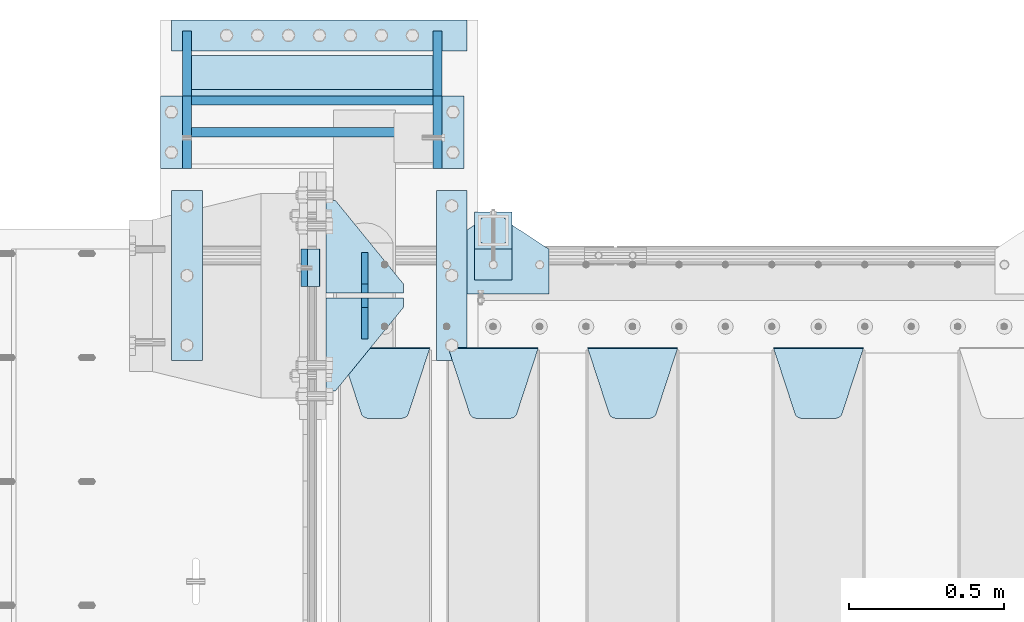
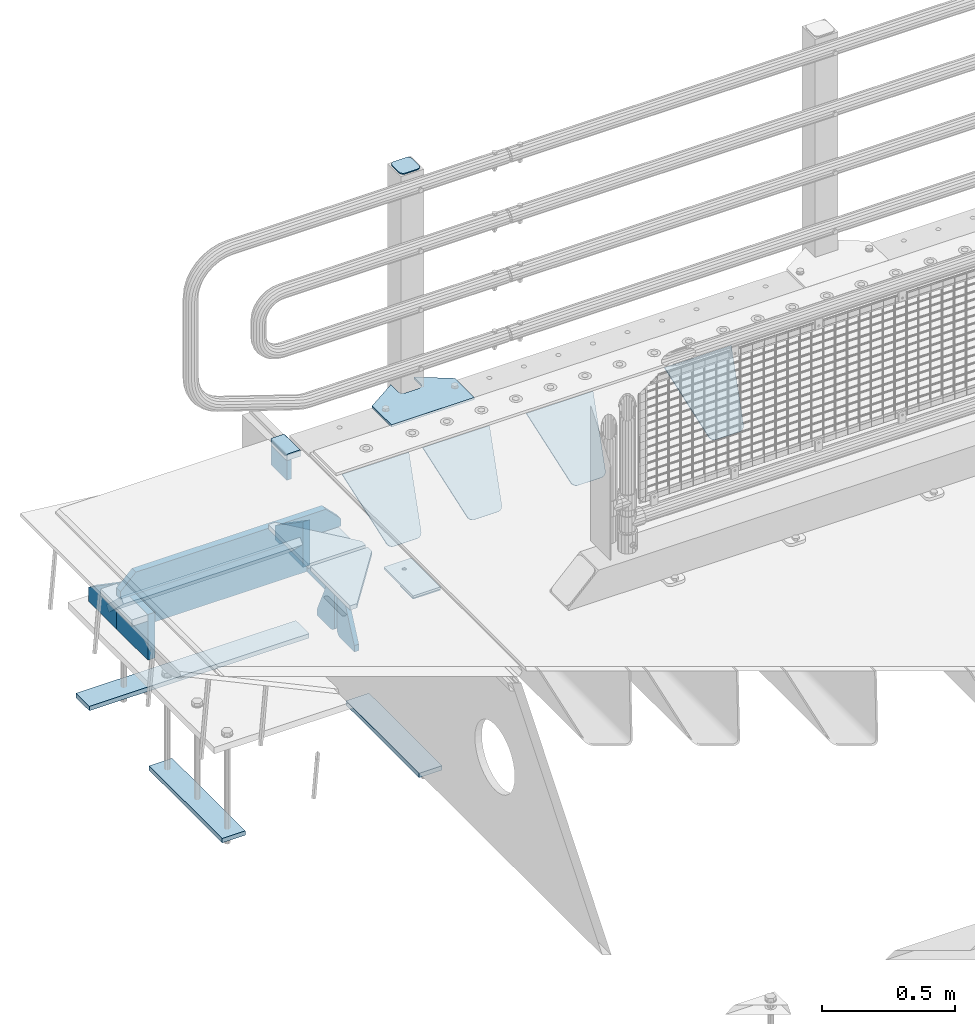
# One storey, part 214 of 240: 26 plates.
"""IFC2X3 building model written with IfcOpenShell, lengths in millimetres."""

from ifc_helpers import new_model, si_unit, frame, origin_with_axes, place, context, subcontext, project, spatial, faceted_brep, material, type_object, element, save


model = new_model("IFC2X3")

# Units and contexts
model_context = context("Model", 3, precision=1e-05, world=origin_with_axes())
body_context = subcontext(model_context, "Body", "Model", "MODEL_VIEW")
ifc_project = project(units=[si_unit("LENGTHUNIT", "METRE", prefix="MILLI"), si_unit("AREAUNIT", "SQUARE_METRE"), si_unit("VOLUMEUNIT", "CUBIC_METRE"), si_unit("MASSUNIT", "GRAM", prefix="KILO"), si_unit("TIMEUNIT", "SECOND"), si_unit("PLANEANGLEUNIT", "RADIAN"), si_unit("SOLIDANGLEUNIT", "STERADIAN"), si_unit("THERMODYNAMICTEMPERATUREUNIT", "DEGREE_CELSIUS"), si_unit("LUMINOUSINTENSITYUNIT", "LUMEN")], contexts=[model_context])

# Site, building, storey
site_placement = place(None, origin_with_axes())
site = spatial("IfcSite", under=ifc_project, at=site_placement, CompositionType="ELEMENT")
building_placement = place(site_placement, origin_with_axes())
building = spatial("IfcBuilding", under=site, at=building_placement, Name="Standard", CompositionType="ELEMENT")
storey_placement = place(building_placement, origin_with_axes())
storey = spatial("IfcBuildingStorey", under=building, at=storey_placement, Name="Undefined", CompositionType="ELEMENT", Elevation=0.0)

# Plates
ifc_material_1 = material()
plate_type_1 = type_object("IfcPlateType", PredefinedType="NOTDEFINED")
plate_1_placement = place(storey_placement, frame((42440.0, 36090.0, -16.0000571405626), z_axis=(-1.0, 0.0, 0.0), x_axis=(0.0, 0.0, 1.0)))
element("IfcPlate", 1, at=plate_1_placement, inside=storey, type_object=plate_type_1, material=ifc_material_1, context=body_context, shape_type="Brep", body=[
    faceted_brep([(3.5527136788005e-15, -60.0, 0.0), (2.49929144047201e-09, -60.0, 60.0), (2.49929144047201e-09, 60.0000000000036, 60.0), (0.0, 60.0000000000036, -7.27595761418343e-12), (25.0146748218828, -59.9999999999964, 60.0), (25.0146748218828, 60.0, 60.0), (26.5597449794466, -60.0, 59.7552873949098), (26.5597449794466, 60.0000000000036, 59.7552873949098), (27.9535758796897, -59.9999999999964, 59.0451032832789), (27.9535758796897, 60.0000000000036, 59.0451032832789), (29.0597323263517, -60.0, 57.9389640667287), (29.0597323263517, 60.0, 57.9389640667287), (29.7699381491534, -59.9999999999964, 56.5451442289705), (29.7699381491534, 60.0000000000036, 56.5451442289705), (30.0146748212763, -60.0, 55.0000778834001), (30.0146748212763, 60.0, 55.0000778834001), (30.0154536553013, -59.9999999999964, 5.00007788340736), (30.0154536553013, 60.0000000000036, 5.00007788340736), (29.7707554908505, -59.9999999999964, 3.45497428546514), (29.7707554908505, 60.0000000000036, 3.45497428546514), (29.0605660948355, -59.9999999999964, 2.06111154406972), (29.0605660948355, 60.0000000000036, 2.06111154406972), (27.9544051209123, -59.9999999999964, 0.954933339693525), (27.9544051209123, 60.0000000000036, 0.954933339693525), (26.5605534420796, -59.9999999999964, 0.244722232011554), (26.5605534420796, 60.0000000000036, 0.244722232011554), (25.0154536559091, -60.0, 7.27595761418343e-12), (25.0154536559091, 60.0, 7.27595761418343e-12)], [[[0, 1, 2, 3]], [[1, 4, 5, 2]], [[4, 6, 7, 5]], [[6, 8, 9, 7]], [[8, 10, 11, 9]], [[10, 12, 13, 11]], [[12, 14, 15, 13]], [[14, 16, 17, 15]], [[16, 18, 19, 17]], [[18, 20, 21, 19]], [[20, 22, 23, 21]], [[22, 24, 25, 23]], [[24, 26, 27, 25]], [[26, 0, 3, 27]], [[5, 7, 9, 11, 13, 15, 17, 19, 21, 23, 25, 27, 3, 2]], [[26, 24, 22, 20, 18, 16, 14, 12, 10, 8, 6, 4, 1, 0]]]),
])
ifc_material_2 = material(Name="STEEL/S355N")
plate_type_2 = type_object("IfcPlateType", PredefinedType="NOTDEFINED")
plate_2_placement = place(storey_placement, frame((42390.0, 36150.0000855346, -105.984391680703), z_axis=(0.0, -1.0, 0.0), x_axis=(0.0, 0.0, 1.0)))
element("IfcPlate", 2, at=plate_2_placement, inside=storey, type_object=plate_type_2, material=ifc_material_2, context=body_context, shape_type="Brep", body=[
    faceted_brep([(0.0, -10.0, 0.0), (5.70725632087488e-07, -10.0, 119.999999999993), (5.70725632087488e-07, 10.0, 119.999999999993), (0.0, 10.0, 0.0), (89.9845046997066, -10.0, 119.999999999996), (89.9845046997066, 10.0, 119.999999999996), (89.9843902587891, -10.0, 6.18456397205591e-11), (89.9843902587891, 10.0, 6.18456397205591e-11)], [[[0, 1, 2, 3]], [[1, 4, 5, 2]], [[4, 6, 7, 5]], [[6, 0, 3, 7]], [[5, 7, 3, 2]], [[6, 4, 1, 0]]]),
])
plate_type_3 = type_object("IfcPlateType", PredefinedType="NOTDEFINED")
plate_3_placement = place(storey_placement, frame((43905.0, 35831.767766956, -1.76776695296758), z_axis=(0.0, -0.707106781186547, -0.707106781186548), x_axis=(1.0, 0.0, 0.0)))
element("IfcPlate", 3, at=plate_3_placement, inside=storey, type_object=plate_type_3, material=ifc_material_2, context=body_context, shape_type="Brep", body=[
    faceted_brep([(0.0, -2.5, 0.0), (69.345504679477, -2.50000000000364, 300.171731424827), (69.345504679477, 2.49999999999636, 300.171731424827), (0.0, 2.5, 0.0), (70.927406119954, -2.50000000000364, 304.897442415397), (70.927406119954, 2.49999999999636, 304.897442415397), (73.3818627772271, -2.50000000000728, 309.234538108525), (73.3818627772271, 2.49999999999636, 309.234538108529), (76.6187032999587, -2.50000000000728, 313.023683126099), (76.6187032999587, 2.49999999999636, 313.023683126103), (80.5190132705029, -2.50000000000364, 316.125672595368), (80.5190132705029, 2.49999999999636, 316.125672595368), (84.9395038596849, -2.50000000000364, 318.426546230472), (84.9395038596849, 2.49999999999636, 318.426546230472), (89.7177759439219, -2.5, 319.841774983277), (89.7177759439219, 2.49999999999636, 319.841774983273), (94.6782862926484, -2.50000000000364, 320.319366455074), (94.6782862926484, 2.49999999999636, 320.319366455074), (195.321713707352, -2.50000000000364, 320.319366455074), (195.321713707352, 2.49999999999636, 320.319366455074), (200.282224056078, -2.50000000000364, 319.841774983273), (200.282224056078, 2.49999999999636, 319.841774983273), (205.060496140315, -2.50000000000364, 318.426546230472), (205.060496140315, 2.49999999999636, 318.426546230472), (209.480986729497, -2.50000000000364, 316.125672595368), (209.480986729497, 2.49999999999636, 316.125672595368), (213.381296700041, -2.50000000000728, 313.023683126099), (213.381296700041, 2.49999999999272, 313.023683126099), (216.618137222766, -2.50000000000364, 309.234538108522), (216.618137222766, 2.49999999999636, 309.234538108522), (219.072593880039, -2.50000000000364, 304.897442415397), (219.072593880039, 2.49999999999636, 304.897442415397), (220.654495320523, -2.50000000000364, 300.171731424827), (220.654495320523, 2.49999999999636, 300.171731424827), (290.0, -2.50000000000364, -3.63797880709171e-12), (290.0, 2.49999999999636, -3.63797880709171e-12)], [[[0, 1, 2, 3]], [[1, 4, 5, 2]], [[4, 6, 7, 5]], [[6, 8, 9, 7]], [[8, 10, 11, 9]], [[10, 12, 13, 11]], [[12, 14, 15, 13]], [[14, 16, 17, 15]], [[16, 18, 19, 17]], [[18, 20, 21, 19]], [[20, 22, 23, 21]], [[22, 24, 25, 23]], [[24, 26, 27, 25]], [[26, 28, 29, 27]], [[28, 30, 31, 29]], [[30, 32, 33, 31]], [[32, 34, 35, 33]], [[34, 0, 3, 35]], [[5, 7, 9, 11, 13, 15, 17, 19, 21, 23, 25, 27, 29, 31, 33, 35, 3, 2]], [[34, 32, 30, 28, 26, 24, 22, 20, 18, 16, 14, 12, 10, 8, 6, 4, 1, 0]]]),
])
plate_4_placement = place(storey_placement, frame((43305.0, 35831.767766956, -1.76776695296758), z_axis=(0.0, -0.707106781186547, -0.707106781186548), x_axis=(1.0, 0.0, 0.0)))
element("IfcPlate", 4, at=plate_4_placement, inside=storey, type_object=plate_type_3, material=ifc_material_2, context=body_context, shape_type="Brep", body=[
    faceted_brep([(0.0, -2.5, 0.0), (69.345504679477, -2.50000000000364, 300.171731424827), (69.345504679477, 2.49999999999636, 300.171731424827), (0.0, 2.5, 0.0), (70.927406119954, -2.50000000000364, 304.897442415397), (70.927406119954, 2.49999999999636, 304.897442415397), (73.3818627772271, -2.50000000000728, 309.234538108525), (73.3818627772271, 2.49999999999636, 309.234538108529), (76.6187032999587, -2.50000000000728, 313.023683126099), (76.6187032999587, 2.49999999999636, 313.023683126103), (80.5190132705029, -2.50000000000364, 316.125672595368), (80.5190132705029, 2.49999999999636, 316.125672595368), (84.9395038596849, -2.50000000000364, 318.426546230472), (84.9395038596849, 2.49999999999636, 318.426546230472), (89.7177759439219, -2.5, 319.841774983277), (89.7177759439219, 2.49999999999636, 319.841774983273), (94.6782862926484, -2.50000000000364, 320.319366455074), (94.6782862926484, 2.49999999999636, 320.319366455074), (195.321713707352, -2.50000000000364, 320.319366455074), (195.321713707352, 2.49999999999636, 320.319366455074), (200.282224056078, -2.50000000000364, 319.841774983273), (200.282224056078, 2.49999999999636, 319.841774983273), (205.060496140315, -2.50000000000364, 318.426546230472), (205.060496140315, 2.49999999999636, 318.426546230472), (209.480986729497, -2.50000000000364, 316.125672595368), (209.480986729497, 2.49999999999636, 316.125672595368), (213.381296700041, -2.50000000000728, 313.023683126099), (213.381296700041, 2.49999999999272, 313.023683126099), (216.618137222766, -2.50000000000364, 309.234538108522), (216.618137222766, 2.49999999999636, 309.234538108522), (219.072593880039, -2.50000000000364, 304.897442415397), (219.072593880039, 2.49999999999636, 304.897442415397), (220.654495320523, -2.50000000000364, 300.171731424827), (220.654495320523, 2.49999999999636, 300.171731424827), (290.0, -2.50000000000364, -3.63797880709171e-12), (290.0, 2.49999999999636, -3.63797880709171e-12)], [[[0, 1, 2, 3]], [[1, 4, 5, 2]], [[4, 6, 7, 5]], [[6, 8, 9, 7]], [[8, 10, 11, 9]], [[10, 12, 13, 11]], [[12, 14, 15, 13]], [[14, 16, 17, 15]], [[16, 18, 19, 17]], [[18, 20, 21, 19]], [[20, 22, 23, 21]], [[22, 24, 25, 23]], [[24, 26, 27, 25]], [[26, 28, 29, 27]], [[28, 30, 31, 29]], [[30, 32, 33, 31]], [[32, 34, 35, 33]], [[34, 0, 3, 35]], [[5, 7, 9, 11, 13, 15, 17, 19, 21, 23, 25, 27, 29, 31, 33, 35, 3, 2]], [[34, 32, 30, 28, 26, 24, 22, 20, 18, 16, 14, 12, 10, 8, 6, 4, 1, 0]]]),
])
plate_5_placement = place(storey_placement, frame((42855.0, 35831.767766956, -1.76776695296758), z_axis=(0.0, -0.707106781186547, -0.707106781186548), x_axis=(1.0, 0.0, 0.0)))
element("IfcPlate", 5, at=plate_5_placement, inside=storey, type_object=plate_type_3, material=ifc_material_2, context=body_context, shape_type="Brep", body=[
    faceted_brep([(0.0, -2.5, 0.0), (69.345504679477, -2.50000000000364, 300.171731424827), (69.345504679477, 2.49999999999636, 300.171731424827), (0.0, 2.5, 0.0), (70.927406119954, -2.50000000000364, 304.897442415397), (70.927406119954, 2.49999999999636, 304.897442415397), (73.3818627772271, -2.50000000000728, 309.234538108525), (73.3818627772271, 2.49999999999636, 309.234538108529), (76.6187032999587, -2.50000000000728, 313.023683126099), (76.6187032999587, 2.49999999999636, 313.023683126103), (80.5190132705029, -2.50000000000364, 316.125672595368), (80.5190132705029, 2.49999999999636, 316.125672595368), (84.9395038596849, -2.50000000000364, 318.426546230472), (84.9395038596849, 2.49999999999636, 318.426546230472), (89.7177759439219, -2.5, 319.841774983277), (89.7177759439219, 2.49999999999636, 319.841774983273), (94.6782862926484, -2.50000000000364, 320.319366455074), (94.6782862926484, 2.49999999999636, 320.319366455074), (195.321713707352, -2.50000000000364, 320.319366455074), (195.321713707352, 2.49999999999636, 320.319366455074), (200.282224056078, -2.50000000000364, 319.841774983273), (200.282224056078, 2.49999999999636, 319.841774983273), (205.060496140315, -2.50000000000364, 318.426546230472), (205.060496140315, 2.49999999999636, 318.426546230472), (209.480986729497, -2.50000000000364, 316.125672595368), (209.480986729497, 2.49999999999636, 316.125672595368), (213.381296700041, -2.50000000000728, 313.023683126099), (213.381296700041, 2.49999999999272, 313.023683126099), (216.618137222766, -2.50000000000364, 309.234538108522), (216.618137222766, 2.49999999999636, 309.234538108522), (219.072593880039, -2.50000000000364, 304.897442415397), (219.072593880039, 2.49999999999636, 304.897442415397), (220.654495320523, -2.50000000000364, 300.171731424827), (220.654495320523, 2.49999999999636, 300.171731424827), (290.0, -2.50000000000364, -3.63797880709171e-12), (290.0, 2.49999999999636, -3.63797880709171e-12)], [[[0, 1, 2, 3]], [[1, 4, 5, 2]], [[4, 6, 7, 5]], [[6, 8, 9, 7]], [[8, 10, 11, 9]], [[10, 12, 13, 11]], [[12, 14, 15, 13]], [[14, 16, 17, 15]], [[16, 18, 19, 17]], [[18, 20, 21, 19]], [[20, 22, 23, 21]], [[22, 24, 25, 23]], [[24, 26, 27, 25]], [[26, 28, 29, 27]], [[28, 30, 31, 29]], [[30, 32, 33, 31]], [[32, 34, 35, 33]], [[34, 0, 3, 35]], [[5, 7, 9, 11, 13, 15, 17, 19, 21, 23, 25, 27, 29, 31, 33, 35, 3, 2]], [[34, 32, 30, 28, 26, 24, 22, 20, 18, 16, 14, 12, 10, 8, 6, 4, 1, 0]]]),
])
plate_6_placement = place(storey_placement, frame((42505.0, 35831.767766956, -1.76776695296758), z_axis=(0.0, -0.707106781186547, -0.707106781186548), x_axis=(1.0, 0.0, 0.0)))
element("IfcPlate", 6, at=plate_6_placement, inside=storey, type_object=plate_type_3, material=ifc_material_2, context=body_context, shape_type="Brep", body=[
    faceted_brep([(0.0, -2.5, 0.0), (69.345504679477, -2.50000000000364, 300.171731424827), (69.345504679477, 2.49999999999636, 300.171731424827), (0.0, 2.5, 0.0), (70.927406119954, -2.50000000000364, 304.897442415397), (70.927406119954, 2.49999999999636, 304.897442415397), (73.3818627772271, -2.50000000000728, 309.234538108525), (73.3818627772271, 2.49999999999636, 309.234538108529), (76.6187032999587, -2.50000000000728, 313.023683126099), (76.6187032999587, 2.49999999999636, 313.023683126103), (80.5190132705029, -2.50000000000364, 316.125672595368), (80.5190132705029, 2.49999999999636, 316.125672595368), (84.9395038596849, -2.50000000000364, 318.426546230472), (84.9395038596849, 2.49999999999636, 318.426546230472), (89.7177759439219, -2.5, 319.841774983277), (89.7177759439219, 2.49999999999636, 319.841774983273), (94.6782862926484, -2.50000000000364, 320.319366455074), (94.6782862926484, 2.49999999999636, 320.319366455074), (195.321713707352, -2.50000000000364, 320.319366455074), (195.321713707352, 2.49999999999636, 320.319366455074), (200.282224056078, -2.50000000000364, 319.841774983273), (200.282224056078, 2.49999999999636, 319.841774983273), (205.060496140315, -2.50000000000364, 318.426546230472), (205.060496140315, 2.49999999999636, 318.426546230472), (209.480986729497, -2.50000000000364, 316.125672595368), (209.480986729497, 2.49999999999636, 316.125672595368), (213.381296700041, -2.50000000000728, 313.023683126099), (213.381296700041, 2.49999999999272, 313.023683126099), (216.618137222766, -2.50000000000364, 309.234538108522), (216.618137222766, 2.49999999999636, 309.234538108522), (219.072593880039, -2.50000000000364, 304.897442415397), (219.072593880039, 2.49999999999636, 304.897442415397), (220.654495320523, -2.50000000000364, 300.171731424827), (220.654495320523, 2.49999999999636, 300.171731424827), (290.0, -2.50000000000364, -3.63797880709171e-12), (290.0, 2.49999999999636, -3.63797880709171e-12)], [[[0, 1, 2, 3]], [[1, 4, 5, 2]], [[4, 6, 7, 5]], [[6, 8, 9, 7]], [[8, 10, 11, 9]], [[10, 12, 13, 11]], [[12, 14, 15, 13]], [[14, 16, 17, 15]], [[16, 18, 19, 17]], [[18, 20, 21, 19]], [[20, 22, 23, 21]], [[22, 24, 25, 23]], [[24, 26, 27, 25]], [[26, 28, 29, 27]], [[28, 30, 31, 29]], [[30, 32, 33, 31]], [[32, 34, 35, 33]], [[34, 0, 3, 35]], [[5, 7, 9, 11, 13, 15, 17, 19, 21, 23, 25, 27, 29, 31, 33, 35, 3, 2]], [[34, 32, 30, 28, 26, 24, 22, 20, 18, 16, 14, 12, 10, 8, 6, 4, 1, 0]]]),
])
plate_type_4 = type_object("IfcPlateType", PredefinedType="NOTDEFINED")
for number, where, z_axis, x_axis in (
    (7, (42710.0, 36008.0, -515.0), (0.0, 1.0, 0.0), (-1.0, 0.0, 0.0)),
    (8, (42710.0, 35992.0, -515.0), (0.0, -1.0, 0.0), (-1.0, 0.0, 0.0)),
):
    element("IfcPlate", number, at=place(storey_placement, frame(where, z_axis=z_axis, x_axis=x_axis)), inside=storey, type_object=plate_type_4, material=ifc_material_2, context=body_context, shape_type="Brep", body=[
        faceted_brep([(0.0, -10.0, 0.0), (0.0, -10.0, 30.0), (0.0, 10.0, 30.0), (0.0, 10.0, 0.0), (220.0, -10.0, 300.0), (220.0, 10.0, 300.0), (250.0, -10.0, 300.0), (250.0, 10.0, 300.0), (250.0, -10.0, 0.0), (250.0, 10.0, 0.0)], [[[0, 1, 2, 3]], [[1, 4, 5, 2]], [[4, 6, 7, 5]], [[6, 8, 9, 7]], [[8, 0, 3, 9]], [[5, 7, 9, 3, 2]], [[8, 6, 4, 1, 0]]]),
    ])
plate_type_5 = type_object("IfcPlateType", PredefinedType="NOTDEFINED")
for number, where, z_axis, x_axis in (
    (9, (42585.0, 35860.0, -860.0), (0.0, 0.0, 1.0), (0.0, 1.0, 0.0)),
    (10, (42585.0, 36140.0, -860.0), (0.0, 0.0, 1.0), (0.0, -1.0, 0.0)),
):
    element("IfcPlate", number, at=place(storey_placement, frame(where, z_axis=z_axis, x_axis=x_axis)), inside=storey, type_object=plate_type_5, material=ifc_material_2, context=body_context, shape_type="Brep", body=[
        faceted_brep([(0.0, -10.0, 0.0), (0.0, -10.0, 30.0), (0.0, 10.0, 30.0), (0.0, 10.0, 0.0), (102.0, -10.0, 250.0), (102.0, 10.0, 250.0), (132.0, -10.0, 250.0), (132.0, 10.0, 250.0), (132.0, -10.0, 30.0), (132.0, 10.0, 30.0), (131.544232590368, -10.0, 24.790554669992), (131.544232590368, 10.0, 24.790554669992), (130.190778623579, -10.0, 19.7393957002299), (130.190778623579, 10.0, 19.7393957002299), (127.980762113533, -10.0, 15.0), (127.980762113533, 10.0, 15.0), (124.98133329357, -10.0, 10.7163717094038), (124.98133329357, 10.0, 10.7163717094038), (121.283628290596, -10.0, 7.01866670643062), (121.283628290596, 10.0, 7.01866670643062), (117.0, -10.0, 4.01923788646684), (117.0, 10.0, 4.01923788646684), (112.260604299769, -10.0, 1.80922137642278), (112.260604299769, 10.0, 1.80922137642278), (107.209445330009, -10.0, 0.455767409633722), (107.209445330009, 10.0, 0.455767409633722), (102.0, -10.0, 0.0), (102.0, 10.0, 0.0)], [[[0, 1, 2, 3]], [[1, 4, 5, 2]], [[4, 6, 7, 5]], [[6, 8, 9, 7]], [[8, 10, 11, 9]], [[10, 12, 13, 11]], [[12, 14, 15, 13]], [[14, 16, 17, 15]], [[16, 18, 19, 17]], [[18, 20, 21, 19]], [[20, 22, 23, 21]], [[22, 24, 25, 23]], [[24, 26, 27, 25]], [[26, 0, 3, 27]], [[5, 7, 9, 11, 13, 15, 17, 19, 21, 23, 25, 27, 3, 2]], [[26, 24, 22, 20, 18, 16, 14, 12, 10, 8, 6, 4, 1, 0]]]),
    ])
ifc_material_3 = material(Name="STEEL/S355J2")
plate_type_6 = type_object("IfcPlateType", PredefinedType="NOTDEFINED")
plate_7_placement = place(storey_placement, frame((42820.0, 36005.0, 5.00000000004911), z_axis=(0.0, 1.0, 0.0), x_axis=(1.0, 0.0, 0.0)))
element("IfcPlate", 11, at=plate_7_placement, inside=storey, type_object=plate_type_6, material=ifc_material_3, context=body_context, shape_type="Brep", body=[
    faceted_brep([(0.0, -5.0, 0.0), (2.31396552408114e-06, -5.0, 145.0), (2.31396552408114e-06, 5.0, 145.0), (0.0, 5.0, 0.0), (130.0, -5.0, 230.0), (130.0, 5.0, 230.0), (130.0, -5.0, 180.0), (130.0, 5.0, 180.0), (130.48036798992, -5.0, 175.122741949599), (130.48036798992, 5.0, 175.122741949599), (131.903011687216, -5.0, 170.432914190875), (131.903011687216, 5.0, 170.432914190875), (134.213259692435, -5.0, 166.110744174512), (134.213259692435, 5.0, 166.110744174512), (137.322330470335, -5.0, 162.322330470335), (137.322330470335, 5.0, 162.322330470335), (141.110744174512, -5.0, 159.213259692435), (141.110744174512, 5.0, 159.213259692435), (145.432914190875, -5.0, 156.903011687216), (145.432914190875, 5.0, 156.903011687216), (150.122741949599, -5.0, 155.48036798992), (150.122741949599, 5.0, 155.48036798992), (155.0, -5.0, 155.0), (155.0, 5.0, 155.0), (205.0, -5.0, 155.0), (205.0, 5.0, 155.0), (209.877258050401, -5.0, 155.48036798992), (209.877258050401, 5.0, 155.48036798992), (214.567085809125, -5.0, 156.903011687216), (214.567085809125, 5.0, 156.903011687216), (218.889255825488, -5.0, 159.213259692435), (218.889255825488, 5.0, 159.213259692435), (222.677669529665, -5.0, 162.322330470335), (222.677669529665, 5.0, 162.322330470335), (225.786740307565, -5.0, 166.110744174512), (225.786740307565, 5.0, 166.110744174512), (228.096988312784, -5.0, 170.432914190875), (228.096988312784, 5.0, 170.432914190875), (229.51963201008, -5.0, 175.122741949599), (229.51963201008, 5.0, 175.122741949599), (230.0, -5.0, 180.0), (230.0, 5.0, 180.0), (230.0, -5.0, 230.0), (230.0, 5.0, 230.0), (360.0, -5.0, 145.0), (360.0, 5.0, 145.0), (360.0, -5.0, -7.27595761418343e-12), (360.0, 5.0, -7.27595761418343e-12)], [[[0, 1, 2, 3]], [[1, 4, 5, 2]], [[4, 6, 7, 5]], [[6, 8, 9, 7]], [[8, 10, 11, 9]], [[10, 12, 13, 11]], [[12, 14, 15, 13]], [[14, 16, 17, 15]], [[16, 18, 19, 17]], [[18, 20, 21, 19]], [[20, 22, 23, 21]], [[22, 24, 25, 23]], [[24, 26, 27, 25]], [[26, 28, 29, 27]], [[28, 30, 31, 29]], [[30, 32, 33, 31]], [[32, 34, 35, 33]], [[34, 36, 37, 35]], [[36, 38, 39, 37]], [[38, 40, 41, 39]], [[40, 42, 43, 41]], [[42, 44, 45, 43]], [[44, 46, 47, 45]], [[46, 0, 3, 47]], [[5, 7, 9, 11, 13, 15, 17, 19, 21, 23, 25, 27, 29, 31, 33, 35, 37, 39, 41, 43, 45, 47, 3, 2]], [[46, 44, 42, 40, 38, 36, 34, 32, 30, 28, 26, 24, 22, 20, 18, 16, 14, 12, 10, 8, 6, 4, 1, 0]]]),
])
plate_type_7 = type_object("IfcPlateType", PredefinedType="NOTDEFINED")
plate_8_placement = place(storey_placement, frame((42940.0000000001, 36050.0000000002, -850.000000000002), z_axis=(0.0, 1.0, 0.0), x_axis=(1.0, 0.0, 0.0)))
element("IfcPlate", 12, at=plate_8_placement, inside=storey, type_object=plate_type_7, material=ifc_material_3, context=body_context, shape_type="Brep", body=[
    faceted_brep([(66.3639610305399, -5.0, 163.636038969111), (66.3639610305399, 5.0, 163.636038969111), (59.9999999998618, 5.0, 160.999999999789), (59.9999999998618, -5.0, 160.999999999789), (53.6360389691836, 5.0, 163.636038969111), (53.6360389691836, -5.0, 163.636038969111), (50.9999999998618, 5.0, 169.999999999789), (50.9999999998618, -5.0, 169.999999999789), (53.6360389691836, 5.0, 176.363961030467), (53.6360389691836, -5.0, 176.363961030467), (59.9999999998618, 5.0, 178.999999999789), (59.9999999998618, -5.0, 178.999999999789), (66.3639610305399, 5.0, 176.363961030467), (66.3639610305399, -5.0, 176.363961030467), (68.9999999998618, 5.0, 169.999999999789), (68.9999999998618, -5.0, 169.999999999789), (120.0, -5.0, 0.0), (120.0, -5.0, 220.0), (0.0, -5.0, 220.0), (0.0, -5.0, 0.0), (0.0, 5.0, 0.0), (120.0, 5.0, 0.0), (120.0, 5.0, 220.0), (0.0, 5.0, 220.0)], [[[0, 1, 2, 3]], [[3, 2, 4, 5]], [[5, 4, 6, 7]], [[7, 6, 8, 9]], [[9, 8, 10, 11]], [[11, 10, 12, 13]], [[13, 12, 14, 15]], [[15, 14, 1, 0]], [[16, 17, 18, 19], [3, 5, 7, 9, 11, 13, 15, 0]], [[16, 19, 20, 21]], [[17, 16, 21, 22]], [[18, 17, 22, 23]], [[19, 18, 23, 20]], [[22, 21, 20, 23], [10, 8, 6, 4, 2, 1, 14, 12]]]),
])
plate_type_8 = type_object("IfcPlateType", PredefinedType="NOTDEFINED")
plate_9_placement = place(storey_placement, frame((43044.0000000001, 36166.0000000002, 1012.50000000001), z_axis=(0.0, 1.0, 0.0), x_axis=(-1.0, 0.0, 0.0)))
element("IfcPlate", 13, at=plate_9_placement, inside=storey, type_object=plate_type_8, material=ifc_material_3, context=body_context, shape_type="Brep", body=[
    faceted_brep([(0.0, -2.5, 19.0), (0.0, -2.5, 69.0), (0.0, 2.5, 69.0), (0.0, 2.5, 19.0), (0.476369668547704, -2.5, 73.2278977451715), (0.476369668547704, 2.5, 73.2278977451715), (1.88159150985302, -2.5, 77.2437910432345), (1.88159150985302, 2.5, 77.2437910432345), (4.14520183311106, -2.5, 80.8463062353185), (4.14520183311106, 2.5, 80.8463062353185), (7.15369376468152, -2.5, 83.8547981668889), (7.15369376468152, 2.5, 83.8547981668889), (10.7562089567655, -2.5, 86.118408490147), (10.7562089567655, 2.5, 86.118408490147), (14.7721022548285, -2.5, 87.5236303314523), (14.7721022548285, 2.5, 87.5236303314523), (19.0, -2.5, 88.0), (19.0, 2.5, 88.0), (69.0, -2.5, 88.0), (69.0, 2.5, 88.0), (73.2278977451715, -2.5, 87.5236303314523), (73.2278977451715, 2.5, 87.5236303314523), (77.2437910432345, -2.5, 86.118408490147), (77.2437910432345, 2.5, 86.118408490147), (80.8463062353185, -2.5, 83.8547981668889), (80.8463062353185, 2.5, 83.8547981668889), (83.8547981668889, -2.5, 80.8463062353185), (83.8547981668889, 2.5, 80.8463062353185), (86.118408490147, -2.5, 77.2437910432345), (86.118408490147, 2.5, 77.2437910432345), (87.5236303314523, -2.5, 73.2278977451715), (87.5236303314523, 2.5, 73.2278977451715), (88.0, -2.5, 69.0), (88.0, 2.5, 69.0), (88.0, -2.5, 19.0), (88.0, 2.5, 19.0), (87.5236303314523, -2.5, 14.7721022548285), (87.5236303314523, 2.5, 14.7721022548285), (86.118408490147, -2.5, 10.7562089567655), (86.118408490147, 2.5, 10.7562089567655), (83.8547981668889, -2.5, 7.15369376468152), (83.8547981668889, 2.5, 7.15369376468152), (80.8463062353185, -2.5, 4.14520183311106), (80.8463062353185, 2.5, 4.14520183311106), (77.2437910432345, -2.5, 1.88159150985302), (77.2437910432345, 2.5, 1.88159150985302), (73.2278977451715, -2.5, 0.476369668547704), (73.2278977451715, 2.5, 0.476369668547704), (69.0, -2.5, 0.0), (69.0, 2.5, 0.0), (19.0, -2.5, 0.0), (19.0, 2.5, 0.0), (14.7721022548285, -2.5, 0.476369668547704), (14.7721022548285, 2.5, 0.476369668547704), (10.7562089567655, -2.5, 1.88159150985302), (10.7562089567655, 2.5, 1.88159150985302), (7.15369376468152, -2.5, 4.14520183311106), (7.15369376468152, 2.5, 4.14520183311106), (4.14520183311106, -2.5, 7.15369376468152), (4.14520183311106, 2.5, 7.15369376468152), (1.88159150985302, -2.5, 10.7562089567655), (1.88159150985302, 2.5, 10.7562089567655), (0.476369668547704, -2.5, 14.7721022548285), (0.476369668547704, 2.5, 14.7721022548285)], [[[0, 1, 2, 3]], [[1, 4, 5, 2]], [[4, 6, 7, 5]], [[6, 8, 9, 7]], [[8, 10, 11, 9]], [[10, 12, 13, 11]], [[12, 14, 15, 13]], [[14, 16, 17, 15]], [[16, 18, 19, 17]], [[18, 20, 21, 19]], [[20, 22, 23, 21]], [[22, 24, 25, 23]], [[24, 26, 27, 25]], [[26, 28, 29, 27]], [[28, 30, 31, 29]], [[30, 32, 33, 31]], [[32, 34, 35, 33]], [[34, 36, 37, 35]], [[36, 38, 39, 37]], [[38, 40, 41, 39]], [[40, 42, 43, 41]], [[42, 44, 45, 43]], [[44, 46, 47, 45]], [[46, 48, 49, 47]], [[48, 50, 51, 49]], [[50, 52, 53, 51]], [[52, 54, 55, 53]], [[54, 56, 57, 55]], [[56, 58, 59, 57]], [[58, 60, 61, 59]], [[60, 62, 63, 61]], [[62, 0, 3, 63]], [[5, 7, 9, 11, 13, 15, 17, 19, 21, 23, 25, 27, 29, 31, 33, 35, 37, 39, 41, 43, 45, 47, 49, 51, 53, 55, 57, 59, 61, 63, 3, 2]], [[62, 60, 58, 56, 54, 52, 50, 48, 46, 44, 42, 40, 38, 36, 34, 32, 30, 28, 26, 24, 22, 20, 18, 16, 14, 12, 10, 8, 6, 4, 1, 0]]]),
])
plate_type_9 = type_object("IfcPlateType", PredefinedType="NOTDEFINED")
plate_10_placement = place(storey_placement, frame((42940.0000000001, 36050.0000000002, -857.500000000002), z_axis=(0.0, 1.0, 0.0), x_axis=(1.0, 0.0, 0.0)))
element("IfcPlate", 14, at=plate_10_placement, inside=storey, type_object=plate_type_9, material=ifc_material_3, context=body_context, shape_type="Brep", body=[
    faceted_brep([(0.0, -2.5, 0.0), (0.0, -2.5, 100.0), (0.0, 2.5, 100.0), (0.0, 2.5, 0.0), (120.0, -2.5, 100.0), (120.0, 2.5, 100.0), (120.0, -2.5, 0.0), (120.0, 2.5, 0.0)], [[[0, 1, 2, 3]], [[1, 4, 5, 2]], [[4, 6, 7, 5]], [[6, 0, 3, 7]], [[5, 7, 3, 2]], [[6, 4, 1, 0]]]),
])
plate_type_10 = type_object("IfcPlateType", PredefinedType="NOTDEFINED")
plate_11_placement = place(storey_placement, frame((42805.0, 36765.3571347532, -1017.14966545659), z_axis=(-1.0, 0.0, 0.0), x_axis=(0.0, -0.723355636225729, 0.690475650215467)))
element("IfcPlate", 15, at=plate_11_placement, inside=storey, type_object=plate_type_10, material=ifc_material_2, context=body_context, shape_type="Brep", body=[
    faceted_brep([(0.0, -15.0, 0.0), (0.0, -14.9999999999964, 779.0), (-3.63797880709171e-12, 15.0000000000036, 779.0), (0.0, 15.0, 0.0), (152.069061279293, -14.9999999999964, 779.0), (152.069061279297, 15.0000000000036, 779.0), (152.069061279293, -14.9999999999964, 0.0), (152.069061279297, 15.0000000000036, 0.0)], [[[0, 1, 2, 3]], [[1, 4, 5, 2]], [[4, 6, 7, 5]], [[6, 0, 3, 7]], [[5, 7, 3, 2]], [[6, 4, 1, 0]]]),
])
plate_type_11 = type_object("IfcPlateType", PredefinedType="NOTDEFINED")
for number, where, z_axis, x_axis in (
    (16, (41961.0, 36339.9999985338, -1468.0), (0.0, -1.0, 0.0), (1.0, 0.0, 0.0)),
    (17, (42816.0, 36339.9999985338, -1468.0), (0.0, -1.0, 0.0), (1.0, 0.0, 0.0)),
):
    element("IfcPlate", number, at=place(storey_placement, frame(where, z_axis=z_axis, x_axis=x_axis)), inside=storey, type_object=plate_type_11, material=ifc_material_2, context=body_context, shape_type="Brep", body=[
        faceted_brep([(0.0, -10.0, 0.0), (1.00942997960374e-06, -10.0, 550.0), (1.00942997960374e-06, 10.0, 550.0), (0.0, 10.0, 0.0), (100.0, -10.0, 550.0), (100.0, 10.0, 550.0), (100.0, -10.0, 0.0), (100.0, 10.0, 0.0)], [[[0, 1, 2, 3]], [[1, 4, 5, 2]], [[4, 6, 7, 5]], [[6, 0, 3, 7]], [[5, 7, 3, 2]], [[6, 4, 1, 0]]]),
    ])
plate_12_placement = place(storey_placement, frame((41961.0, 36889.9999985338, -1468.0), z_axis=(0.0, -1.0, 0.0), x_axis=(1.0, 0.0, 0.0)))
element("IfcPlate", 18, at=plate_12_placement, inside=storey, type_object=plate_type_11, material=ifc_material_2, context=body_context, shape_type="Brep", body=[
    faceted_brep([(0.0, -10.0, 0.0), (0.0, -10.0, 100.0), (0.0, 10.0, 100.0), (0.0, 10.0, 0.0), (955.0, -10.0, 100.0), (955.0, 10.0, 100.0), (955.0, -10.0, 0.0), (955.0, 10.0, 0.0)], [[[0, 1, 2, 3]], [[1, 4, 5, 2]], [[4, 6, 7, 5]], [[6, 0, 3, 7]], [[5, 7, 3, 2]], [[6, 4, 1, 0]]]),
])
plate_type_12 = type_object("IfcPlateType", PredefinedType="NOTDEFINED")
for number, where, z_axis, x_axis in (
    (19, (42820.0, 36855.0, -1028.0), (0.0, 0.0, 1.0), (0.0, -1.0, 0.0)),
    (20, (42011.0, 36855.0, -1028.0), (0.0, 0.0, 1.0), (0.0, -1.0, 0.0)),
):
    element("IfcPlate", number, at=place(storey_placement, frame(where, z_axis=z_axis, x_axis=x_axis)), inside=storey, type_object=plate_type_12, material=ifc_material_2, context=body_context, shape_type="Brep", body=[
        faceted_brep([(0.0, -15.0, 0.0), (0.0, -15.0, 66.0), (0.0, 15.0, 66.0), (0.0, 15.0, 0.0), (210.0, -15.0, 210.0), (210.0, 15.0, 210.0), (210.0, -15.0, 0.0), (210.0, 15.0, 0.0)], [[[0, 1, 2, 3]], [[1, 4, 5, 2]], [[4, 6, 7, 5]], [[6, 0, 3, 7]], [[5, 7, 3, 2]], [[6, 4, 1, 0]]]),
    ])
plate_13_placement = place(storey_placement, frame((42820.0, 36410.0, -818.000000000005), z_axis=(0.0, 0.0, -1.0), x_axis=(0.0, 1.0, 0.0)))
element("IfcPlate", 21, at=plate_13_placement, inside=storey, type_object=plate_type_12, material=ifc_material_2, context=body_context, shape_type="Brep", body=[
    faceted_brep([(0.0, -15.0, 0.0), (0.0, -15.0, 210.0), (0.0, 15.0, 210.0), (0.0, 15.0, 0.0), (235.0, -15.0, 210.0), (235.0, 15.0, 210.0), (235.0, -15.0, 0.0), (235.0, 15.0, 0.0)], [[[0, 1, 2, 3]], [[1, 4, 5, 2]], [[4, 6, 7, 5]], [[6, 0, 3, 7]], [[5, 7, 3, 2]], [[6, 4, 1, 0]]]),
])
plate_14_placement = place(storey_placement, frame((42026.0, 36630.0, -1028.0), z_axis=(1.0, 0.0, 0.0), x_axis=(0.0, 0.0, 1.0)))
element("IfcPlate", 22, at=plate_14_placement, inside=storey, type_object=plate_type_12, material=ifc_material_2, context=body_context, shape_type="Brep", body=[
    faceted_brep([(0.0, -15.0, 0.0), (0.0, -14.9999999999964, 779.0), (-3.63797880709171e-12, 15.0000000000036, 779.0), (0.0, 15.0, 0.0), (210.0, -15.0, 779.0), (210.0, 15.0, 779.0), (210.0, -15.0, 0.0), (210.0, 15.0, 0.0)], [[[0, 1, 2, 3]], [[1, 4, 5, 2]], [[4, 6, 7, 5]], [[6, 0, 3, 7]], [[5, 7, 3, 2]], [[6, 4, 1, 0]]]),
])
plate_15_placement = place(storey_placement, frame((42011.0, 36410.0, -818.000000000004), z_axis=(0.0, 0.0, -1.0), x_axis=(0.0, 1.0, 0.0)))
element("IfcPlate", 23, at=plate_15_placement, inside=storey, type_object=plate_type_12, material=ifc_material_2, context=body_context, shape_type="Brep", body=[
    faceted_brep([(0.0, -15.0, 0.0), (0.0, -15.0, 210.0), (0.0, 15.0, 210.0), (0.0, 15.0, 0.0), (235.0, -15.0, 210.0), (235.0, 15.0, 210.0), (235.0, -15.0, 0.0), (235.0, 15.0, 0.0)], [[[0, 1, 2, 3]], [[1, 4, 5, 2]], [[4, 6, 7, 5]], [[6, 0, 3, 7]], [[5, 7, 3, 2]], [[6, 4, 1, 0]]]),
])
plate_type_13 = type_object("IfcPlateType", PredefinedType="NOTDEFINED")
plate_16_placement = place(storey_placement, frame((41936.0, 36527.5, -788.000000000004), z_axis=(0.0, 0.0, 1.0), x_axis=(1.0, 0.0, 0.0)))
element("IfcPlate", 24, at=plate_16_placement, inside=storey, type_object=plate_type_13, material=ifc_material_2, context=body_context, shape_type="Brep", body=[
    faceted_brep([(0.0, -15.0, 0.0), (0.0, -15.0, 33.0), (0.0, 15.0, 33.0), (0.0, 15.0, 0.0), (67.0, -15.0, 100.0), (67.0, 15.0, 100.0), (892.0, -15.0, 100.0), (892.0, 15.0, 100.0), (959.0, -15.0, 33.0), (959.0, 15.0, 33.0), (959.0, -15.0, 0.0), (959.0, 15.0, 0.0)], [[[0, 1, 2, 3]], [[1, 4, 5, 2]], [[4, 6, 7, 5]], [[6, 8, 9, 7]], [[8, 10, 11, 9]], [[10, 0, 3, 11]], [[5, 7, 9, 11, 3, 2]], [[10, 8, 6, 4, 1, 0]]]),
])
plate_type_14 = type_object("IfcPlateType", PredefinedType="NOTDEFINED")
for number, where, z_axis, x_axis in (
    (25, (42835.0, 36645.0, -833.000000000004), (1.0, 0.0, 0.0), (0.0, -1.0, 0.0)),
    (26, (41926.0, 36645.0, -833.000000000004), (1.0, 0.0, 0.0), (0.0, -1.0, 0.0)),
):
    element("IfcPlate", number, at=place(storey_placement, frame(where, z_axis=z_axis, x_axis=x_axis)), inside=storey, type_object=plate_type_14, material=ifc_material_2, context=body_context, shape_type="Brep", body=[
        faceted_brep([(0.0, -15.0, 0.0), (0.0, -15.0, 70.0), (0.0, 15.0, 70.0), (0.0, 15.0, 0.0), (235.0, -15.0, 70.0), (235.0, 15.0, 70.0), (235.0, -15.0, 0.0), (235.0, 15.0, 0.0)], [[[0, 1, 2, 3]], [[1, 4, 5, 2]], [[4, 6, 7, 5]], [[6, 0, 3, 7]], [[5, 7, 3, 2]], [[6, 4, 1, 0]]]),
    ])

save(model, "model.ifc")
